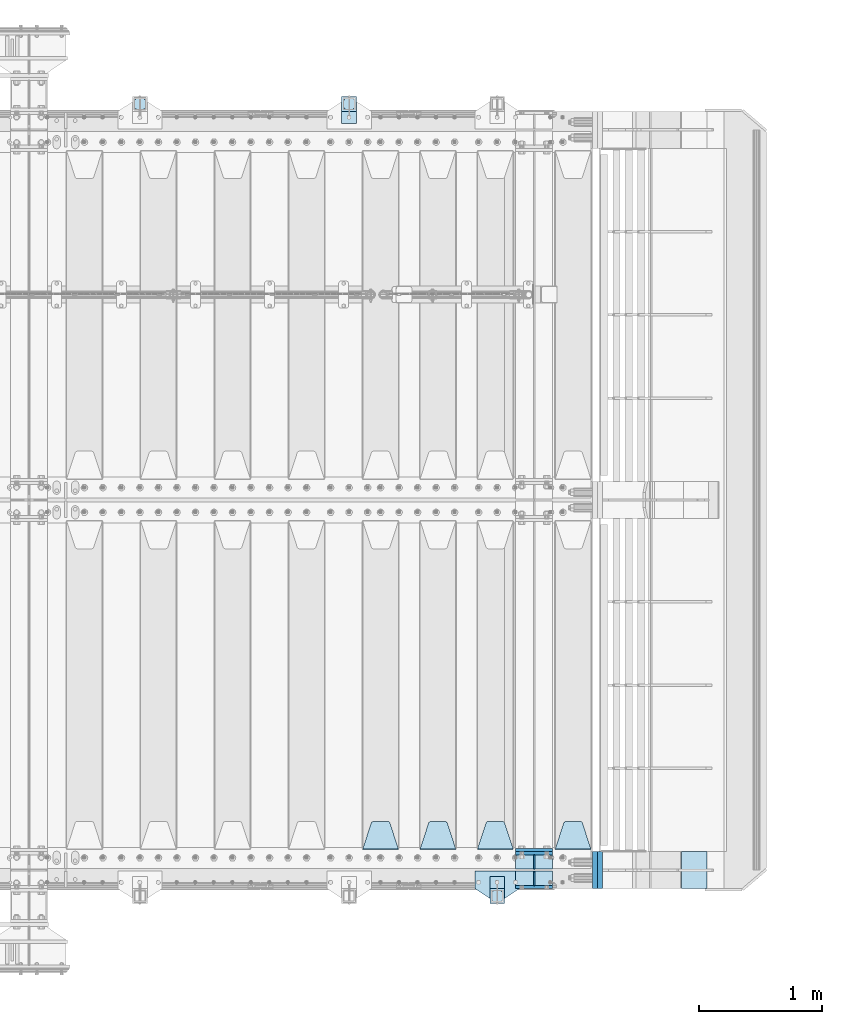
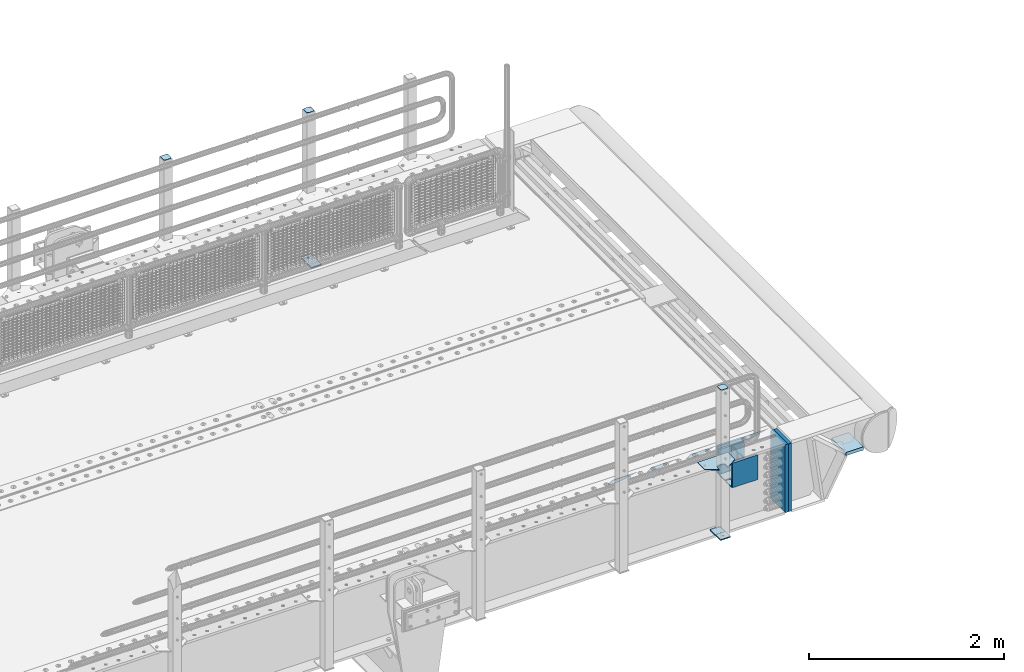
# One storey, part 188 of 208: 22 plates.
"""IFC2X3 building model written with IfcOpenShell, lengths in millimetres."""

from ifc_helpers import new_model, si_unit, frame, origin_with_axes, place, context, subcontext, project, spatial, faceted_brep, material, type_object, element, save


model = new_model("IFC2X3")

# Units and contexts
model_context = context("Model", 3, precision=1e-05, world=origin_with_axes())
body_context = subcontext(model_context, "Body", "Model", "MODEL_VIEW")
ifc_project = project(units=[si_unit("LENGTHUNIT", "METRE", prefix="MILLI"), si_unit("AREAUNIT", "SQUARE_METRE"), si_unit("VOLUMEUNIT", "CUBIC_METRE"), si_unit("MASSUNIT", "GRAM", prefix="KILO"), si_unit("TIMEUNIT", "SECOND"), si_unit("PLANEANGLEUNIT", "RADIAN"), si_unit("SOLIDANGLEUNIT", "STERADIAN"), si_unit("THERMODYNAMICTEMPERATUREUNIT", "DEGREE_CELSIUS"), si_unit("LUMINOUSINTENSITYUNIT", "LUMEN")], contexts=[model_context])

# Site, building, storey
site_placement = place(None, origin_with_axes())
site = spatial("IfcSite", under=ifc_project, at=site_placement, CompositionType="ELEMENT")
building_placement = place(site_placement, origin_with_axes())
building = spatial("IfcBuilding", under=site, at=building_placement, Name="Standard", CompositionType="ELEMENT")
storey_placement = place(building_placement, origin_with_axes())
storey = spatial("IfcBuildingStorey", under=building, at=storey_placement, Name="Undefined", CompositionType="ELEMENT", Elevation=0.0)

# Plates
ifc_material_1 = material(Name="STEEL/S355N")
plate_type_1 = type_object("IfcPlateType", PredefinedType="NOTDEFINED")
for number, where, z_axis, x_axis in (
    (1, (-26255.0, 137.499999999987, -339.999999999993), (0.0, 0.0, 1.0), (1.0, 0.0, 0.0)),
    (2, (-26255.0, -137.500000000013, -339.999999999993), (0.0, 0.0, 1.0), (1.0, 0.0, 0.0)),
):
    element("IfcPlate", number, at=place(storey_placement, frame(where, z_axis=z_axis, x_axis=x_axis)), inside=storey, type_object=plate_type_1, material=ifc_material_1, context=body_context, shape_type="Brep", body=[
        faceted_brep([(0.0, -12.5, 0.0), (0.0, -12.5, 310.0), (0.0, 12.5, 310.0), (0.0, 12.5, 0.0), (300.0, -12.5, 310.0), (300.0, 12.5, 310.0), (300.0, -12.5, 0.0), (300.0, 12.5, 0.0)], [[[0, 1, 2, 3]], [[1, 4, 5, 2]], [[4, 6, 7, 5]], [[6, 0, 3, 7]], [[5, 7, 3, 2]], [[6, 4, 1, 0]]]),
    ])
plate_1_placement = place(storey_placement, frame((-26255.0, 162.5, -340.000000000044), z_axis=(0.0, 0.0, 1.0), x_axis=(1.0, 0.0, 0.0)))
element("IfcPlate", 3, at=plate_1_placement, inside=storey, type_object=plate_type_1, material=ifc_material_1, context=body_context, shape_type="Brep", body=[
    faceted_brep([(0.0, -12.5, 0.0), (0.0, -12.5, 340.0), (0.0, 12.5, 340.0), (0.0, 12.5, 0.0), (300.0, -12.5, 340.0), (300.0, 12.5, 340.0), (300.0, -12.5, 0.0), (300.0, 12.5, 0.0)], [[[0, 1, 2, 3]], [[1, 4, 5, 2]], [[4, 6, 7, 5]], [[6, 0, 3, 7]], [[5, 7, 3, 2]], [[6, 4, 1, 0]]]),
])
plate_type_2 = type_object("IfcPlateType", PredefinedType="NOTDEFINED")
for number, where, z_axis, x_axis in (
    (4, (-26255.0, -8.0000000000133, -342.999999999993), (0.0, -1.0, 0.0), (1.0, 0.0, 0.0)),
    (5, (-26255.0, 7.9999999999867, -342.999999999993), (0.0, 1.0, 0.0), (1.0, 0.0, 0.0)),
):
    element("IfcPlate", number, at=place(storey_placement, frame(where, z_axis=z_axis, x_axis=x_axis)), inside=storey, type_object=plate_type_2, material=ifc_material_1, context=body_context, shape_type="Brep", body=[
        faceted_brep([(0.0, -7.0, 0.0), (0.0, -7.0, 117.0), (0.0, 7.0, 117.0), (0.0, 7.0, 0.0), (300.0, -7.0, 117.0), (300.0, 7.0, 117.0), (300.0, -7.0, 0.0), (300.0, 7.0, 0.0)], [[[0, 1, 2, 3]], [[1, 4, 5, 2]], [[4, 6, 7, 5]], [[6, 0, 3, 7]], [[5, 7, 3, 2]], [[6, 4, 1, 0]]]),
    ])
plate_type_3 = type_object("IfcPlateType", PredefinedType="NOTDEFINED")
for number, where, z_axis, x_axis in (
    (6, (-26105.0, 7.9999999999867, -29.999999999993), (0.0, 0.0, -1.0), (0.0, 1.0, 0.0)),
    (7, (-26105.0, -8.0000000000133, -29.999999999993), (0.0, 0.0, -1.0), (0.0, -1.0, 0.0)),
):
    element("IfcPlate", number, at=place(storey_placement, frame(where, z_axis=z_axis, x_axis=x_axis)), inside=storey, type_object=plate_type_3, material=ifc_material_1, context=body_context, shape_type="Brep", body=[
        faceted_brep([(0.0, -5.0, 30.0), (0.0, -5.0, 306.0), (0.0, 5.0, 306.0), (0.0, 5.0, 30.0), (117.0, -5.0, 306.0), (117.0, 5.0, 306.0), (117.0, -5.0, 0.0), (117.0, 5.0, 0.0), (30.0, -5.0, 0.0), (30.0, 5.0, 0.0), (24.7905546699922, -5.0, 0.455767409633758), (24.7905546699922, 5.0, 0.455767409633758), (19.7393957002296, -5.0, 1.80922137642275), (19.7393957002296, 5.0, 1.80922137642275), (15.0, -5.0, 4.01923788646684), (15.0, 5.0, 4.01923788646684), (10.7163717094036, -5.0, 7.01866670643066), (10.7163717094036, 5.0, 7.01866670643066), (7.01866670643085, -5.0, 10.7163717094038), (7.01866670643085, 5.0, 10.7163717094038), (4.01923788646673, -5.0, 15.0), (4.01923788646673, 5.0, 15.0), (1.80922137642301, -5.0, 19.7393957002299), (1.80922137642301, 5.0, 19.7393957002299), (0.455767409634063, -5.0, 24.7905546699921), (0.455767409634063, 5.0, 24.7905546699921)], [[[0, 1, 2, 3]], [[1, 4, 5, 2]], [[4, 6, 7, 5]], [[6, 8, 9, 7]], [[8, 10, 11, 9]], [[10, 12, 13, 11]], [[12, 14, 15, 13]], [[14, 16, 17, 15]], [[16, 18, 19, 17]], [[18, 20, 21, 19]], [[20, 22, 23, 21]], [[22, 24, 25, 23]], [[24, 0, 3, 25]], [[5, 7, 9, 11, 13, 15, 17, 19, 21, 23, 25, 3, 2]], [[24, 22, 20, 18, 16, 14, 12, 10, 8, 6, 4, 1, 0]]]),
    ])
plate_type_4 = type_object("IfcPlateType", PredefinedType="NOTDEFINED")
plate_2_placement = place(storey_placement, frame((-25645.0, 168.232233047019, -1.76776695296758), z_axis=(0.0, 0.707106781186547, -0.707106781186548), x_axis=(-1.0, 0.0, 0.0)))
element("IfcPlate", 8, at=plate_2_placement, inside=storey, type_object=plate_type_4, material=ifc_material_1, context=body_context, shape_type="Brep", body=[
    faceted_brep([(0.0, -2.5, 0.0), (69.345504679477, -2.5, 300.17173142483), (69.345504679477, 2.5, 300.17173142483), (0.0, 2.5, 0.0), (70.9274061199576, -2.5, 304.897442415399), (70.9274061199576, 2.5, 304.8974424154), (73.3818627772307, -2.5, 309.234538108527), (73.3818627772307, 2.5, 309.234538108527), (76.6187032999551, -2.5, 313.023683126103), (76.6187032999551, 2.5, 313.023683126103), (80.5190132704993, -2.5, 316.125672595371), (80.5190132704993, 2.5, 316.125672595371), (84.9395038596849, -2.5, 318.426546230476), (84.9395038596849, 2.50000000000091, 318.426546230476), (89.7177759439219, -2.5, 319.841774983275), (89.7177759439219, 2.50000000000091, 319.841774983275), (94.678286292652, -2.49999999999909, 320.319366455078), (94.678286292652, 2.5, 320.319366455078), (195.321713707348, -2.49999999999909, 320.319366455078), (195.321713707348, 2.5, 320.319366455078), (200.282224056078, -2.5, 319.841774983275), (200.282224056078, 2.5, 319.841774983274), (205.060496140315, -2.5, 318.426546230475), (205.060496140315, 2.5, 318.426546230475), (209.480986729501, -2.5, 316.125672595371), (209.480986729501, 2.50000000000091, 316.125672595371), (213.381296700045, -2.5, 313.023683126102), (213.381296700045, 2.5, 313.023683126102), (216.618137222769, -2.5, 309.234538108526), (216.618137222769, 2.5, 309.234538108527), (219.072593880042, -2.5, 304.897442415399), (219.072593880042, 2.5, 304.897442415399), (220.654495320523, -2.5, 300.17173142483), (220.654495320523, 2.5, 300.17173142483), (290.0, -2.5, 0.0), (290.0, 2.5, 0.0)], [[[0, 1, 2, 3]], [[1, 4, 5, 2]], [[4, 6, 7, 5]], [[6, 8, 9, 7]], [[8, 10, 11, 9]], [[10, 12, 13, 11]], [[12, 14, 15, 13]], [[14, 16, 17, 15]], [[16, 18, 19, 17]], [[18, 20, 21, 19]], [[20, 22, 23, 21]], [[22, 24, 25, 23]], [[24, 26, 27, 25]], [[26, 28, 29, 27]], [[28, 30, 31, 29]], [[30, 32, 33, 31]], [[32, 34, 35, 33]], [[34, 0, 3, 35]], [[5, 7, 9, 11, 13, 15, 17, 19, 21, 23, 25, 27, 29, 31, 33, 35, 3, 2]], [[34, 32, 30, 28, 26, 24, 22, 20, 18, 16, 14, 12, 10, 8, 6, 4, 1, 0]]]),
])
plate_3_placement = place(storey_placement, frame((-26275.0, 168.232233047019, -1.76776695296758), z_axis=(0.0, 0.707106781186547, -0.707106781186548), x_axis=(-1.0, 0.0, 0.0)))
element("IfcPlate", 9, at=plate_3_placement, inside=storey, type_object=plate_type_4, material=ifc_material_1, context=body_context, shape_type="Brep", body=[
    faceted_brep([(0.0, -2.5, 0.0), (69.345504679477, -2.5, 300.17173142483), (69.345504679477, 2.5, 300.17173142483), (0.0, 2.5, 0.0), (70.9274061199576, -2.5, 304.897442415399), (70.9274061199576, 2.5, 304.8974424154), (73.3818627772307, -2.5, 309.234538108527), (73.3818627772307, 2.5, 309.234538108527), (76.6187032999551, -2.5, 313.023683126103), (76.6187032999551, 2.5, 313.023683126103), (80.5190132704993, -2.5, 316.125672595371), (80.5190132704993, 2.5, 316.125672595371), (84.9395038596849, -2.5, 318.426546230476), (84.9395038596849, 2.50000000000091, 318.426546230476), (89.7177759439219, -2.5, 319.841774983275), (89.7177759439219, 2.50000000000091, 319.841774983275), (94.678286292652, -2.49999999999909, 320.319366455078), (94.678286292652, 2.5, 320.319366455078), (195.321713707348, -2.49999999999909, 320.319366455078), (195.321713707348, 2.5, 320.319366455078), (200.282224056078, -2.5, 319.841774983275), (200.282224056078, 2.5, 319.841774983274), (205.060496140315, -2.5, 318.426546230475), (205.060496140315, 2.5, 318.426546230475), (209.480986729501, -2.5, 316.125672595371), (209.480986729501, 2.50000000000091, 316.125672595371), (213.381296700045, -2.5, 313.023683126102), (213.381296700045, 2.5, 313.023683126102), (216.618137222769, -2.5, 309.234538108526), (216.618137222769, 2.5, 309.234538108527), (219.072593880042, -2.5, 304.897442415399), (219.072593880042, 2.5, 304.897442415399), (220.654495320523, -2.5, 300.17173142483), (220.654495320523, 2.5, 300.17173142483), (290.0, -2.5, 0.0), (290.0, 2.5, 0.0)], [[[0, 1, 2, 3]], [[1, 4, 5, 2]], [[4, 6, 7, 5]], [[6, 8, 9, 7]], [[8, 10, 11, 9]], [[10, 12, 13, 11]], [[12, 14, 15, 13]], [[14, 16, 17, 15]], [[16, 18, 19, 17]], [[18, 20, 21, 19]], [[20, 22, 23, 21]], [[22, 24, 25, 23]], [[24, 26, 27, 25]], [[26, 28, 29, 27]], [[28, 30, 31, 29]], [[30, 32, 33, 31]], [[32, 34, 35, 33]], [[34, 0, 3, 35]], [[5, 7, 9, 11, 13, 15, 17, 19, 21, 23, 25, 27, 29, 31, 33, 35, 3, 2]], [[34, 32, 30, 28, 26, 24, 22, 20, 18, 16, 14, 12, 10, 8, 6, 4, 1, 0]]]),
])
plate_4_placement = place(storey_placement, frame((-26740.0, 168.232233047019, -1.76776695296758), z_axis=(0.0, 0.707106781186547, -0.707106781186548), x_axis=(-1.0, 0.0, 0.0)))
element("IfcPlate", 10, at=plate_4_placement, inside=storey, type_object=plate_type_4, material=ifc_material_1, context=body_context, shape_type="Brep", body=[
    faceted_brep([(0.0, -2.5, 0.0), (69.345504679477, -2.5, 300.17173142483), (69.345504679477, 2.5, 300.17173142483), (0.0, 2.5, 0.0), (70.9274061199576, -2.5, 304.897442415399), (70.9274061199576, 2.5, 304.8974424154), (73.3818627772307, -2.5, 309.234538108527), (73.3818627772307, 2.5, 309.234538108527), (76.6187032999551, -2.5, 313.023683126103), (76.6187032999551, 2.5, 313.023683126103), (80.5190132704993, -2.5, 316.125672595371), (80.5190132704993, 2.5, 316.125672595371), (84.9395038596849, -2.5, 318.426546230476), (84.9395038596849, 2.50000000000091, 318.426546230476), (89.7177759439219, -2.5, 319.841774983275), (89.7177759439219, 2.50000000000091, 319.841774983275), (94.678286292652, -2.49999999999909, 320.319366455078), (94.678286292652, 2.5, 320.319366455078), (195.321713707348, -2.49999999999909, 320.319366455078), (195.321713707348, 2.5, 320.319366455078), (200.282224056078, -2.5, 319.841774983275), (200.282224056078, 2.5, 319.841774983274), (205.060496140315, -2.5, 318.426546230475), (205.060496140315, 2.5, 318.426546230475), (209.480986729501, -2.5, 316.125672595371), (209.480986729501, 2.50000000000091, 316.125672595371), (213.381296700045, -2.5, 313.023683126102), (213.381296700045, 2.5, 313.023683126102), (216.618137222769, -2.5, 309.234538108526), (216.618137222769, 2.5, 309.234538108527), (219.072593880042, -2.5, 304.897442415399), (219.072593880042, 2.5, 304.897442415399), (220.654495320523, -2.5, 300.17173142483), (220.654495320523, 2.5, 300.17173142483), (290.0, -2.5, 0.0), (290.0, 2.5, 0.0)], [[[0, 1, 2, 3]], [[1, 4, 5, 2]], [[4, 6, 7, 5]], [[6, 8, 9, 7]], [[8, 10, 11, 9]], [[10, 12, 13, 11]], [[12, 14, 15, 13]], [[14, 16, 17, 15]], [[16, 18, 19, 17]], [[18, 20, 21, 19]], [[20, 22, 23, 21]], [[22, 24, 25, 23]], [[24, 26, 27, 25]], [[26, 28, 29, 27]], [[28, 30, 31, 29]], [[30, 32, 33, 31]], [[32, 34, 35, 33]], [[34, 0, 3, 35]], [[5, 7, 9, 11, 13, 15, 17, 19, 21, 23, 25, 27, 29, 31, 33, 35, 3, 2]], [[34, 32, 30, 28, 26, 24, 22, 20, 18, 16, 14, 12, 10, 8, 6, 4, 1, 0]]]),
])
plate_5_placement = place(storey_placement, frame((-27205.0, 168.232233047019, -1.76776695296758), z_axis=(0.0, 0.707106781186547, -0.707106781186548), x_axis=(-1.0, 0.0, 0.0)))
element("IfcPlate", 11, at=plate_5_placement, inside=storey, type_object=plate_type_4, material=ifc_material_1, context=body_context, shape_type="Brep", body=[
    faceted_brep([(0.0, -2.5, 0.0), (69.345504679477, -2.5, 300.17173142483), (69.345504679477, 2.5, 300.17173142483), (0.0, 2.5, 0.0), (70.9274061199576, -2.5, 304.897442415399), (70.9274061199576, 2.5, 304.8974424154), (73.3818627772307, -2.5, 309.234538108527), (73.3818627772307, 2.5, 309.234538108527), (76.6187032999551, -2.5, 313.023683126103), (76.6187032999551, 2.5, 313.023683126103), (80.5190132704993, -2.5, 316.125672595371), (80.5190132704993, 2.5, 316.125672595371), (84.9395038596849, -2.5, 318.426546230476), (84.9395038596849, 2.50000000000091, 318.426546230476), (89.7177759439219, -2.5, 319.841774983275), (89.7177759439219, 2.50000000000091, 319.841774983275), (94.678286292652, -2.49999999999909, 320.319366455078), (94.678286292652, 2.5, 320.319366455078), (195.321713707348, -2.49999999999909, 320.319366455078), (195.321713707348, 2.5, 320.319366455078), (200.282224056078, -2.5, 319.841774983275), (200.282224056078, 2.5, 319.841774983274), (205.060496140315, -2.5, 318.426546230475), (205.060496140315, 2.5, 318.426546230475), (209.480986729501, -2.5, 316.125672595371), (209.480986729501, 2.50000000000091, 316.125672595371), (213.381296700045, -2.5, 313.023683126102), (213.381296700045, 2.5, 313.023683126102), (216.618137222769, -2.5, 309.234538108526), (216.618137222769, 2.5, 309.234538108527), (219.072593880042, -2.5, 304.897442415399), (219.072593880042, 2.5, 304.897442415399), (220.654495320523, -2.5, 300.17173142483), (220.654495320523, 2.5, 300.17173142483), (290.0, -2.5, 0.0), (290.0, 2.5, 0.0)], [[[0, 1, 2, 3]], [[1, 4, 5, 2]], [[4, 6, 7, 5]], [[6, 8, 9, 7]], [[8, 10, 11, 9]], [[10, 12, 13, 11]], [[12, 14, 15, 13]], [[14, 16, 17, 15]], [[16, 18, 19, 17]], [[18, 20, 21, 19]], [[20, 22, 23, 21]], [[22, 24, 25, 23]], [[24, 26, 27, 25]], [[26, 28, 29, 27]], [[28, 30, 31, 29]], [[30, 32, 33, 31]], [[32, 34, 35, 33]], [[34, 0, 3, 35]], [[5, 7, 9, 11, 13, 15, 17, 19, 21, 23, 25, 27, 29, 31, 33, 35, 3, 2]], [[34, 32, 30, 28, 26, 24, 22, 20, 18, 16, 14, 12, 10, 8, 6, 4, 1, 0]]]),
])
ifc_material_2 = material(Name="STEEL/S355J2")
plate_type_5 = type_object("IfcPlateType", PredefinedType="NOTDEFINED")
plate_6_placement = place(storey_placement, frame((-26225.0, -4.99999999999636, 5.00000000004911), z_axis=(0.0, -1.0, 0.0), x_axis=(-1.0, 0.0, 0.0)))
element("IfcPlate", 12, at=plate_6_placement, inside=storey, type_object=plate_type_5, material=ifc_material_2, context=body_context, shape_type="Brep", body=[
    faceted_brep([(0.0, -5.0, 0.0), (2.31396552408114e-06, -5.0, 145.0), (2.31396552408114e-06, 5.0, 145.0), (0.0, 5.0, 0.0), (130.0, -5.0, 230.0), (130.0, 5.0, 230.0), (130.0, -5.0, 180.0), (130.0, 5.0, 180.0), (130.48036798992, -5.0, 175.122741949597), (130.48036798992, 5.0, 175.122741949597), (131.903011687216, -5.0, 170.432914190873), (131.903011687216, 5.0, 170.432914190873), (134.213259692435, -5.0, 166.11074417451), (134.213259692435, 5.0, 166.11074417451), (137.322330470335, -5.0, 162.322330470336), (137.322330470335, 5.0, 162.322330470336), (141.110744174512, -5.0, 159.213259692437), (141.110744174512, 5.0, 159.213259692437), (145.432914190871, -5.0, 156.903011687218), (145.432914190871, 5.0, 156.903011687218), (150.122741949595, -5.0, 155.48036798992), (150.122741949595, 5.0, 155.48036798992), (155.0, -5.0, 155.0), (155.0, 5.0, 155.0), (205.0, -5.0, 155.0), (205.0, 5.0, 155.0), (209.877258050405, -5.0, 155.48036798992), (209.877258050405, 5.0, 155.48036798992), (214.567085809129, -5.0, 156.903011687218), (214.567085809129, 5.0, 156.903011687218), (218.889255825488, -5.0, 159.213259692437), (218.889255825488, 5.0, 159.213259692437), (222.677669529665, -5.0, 162.322330470336), (222.677669529665, 5.0, 162.322330470336), (225.786740307565, -5.0, 166.11074417451), (225.786740307565, 5.0, 166.11074417451), (228.096988312784, -5.0, 170.432914190873), (228.096988312784, 5.0, 170.432914190873), (229.51963201008, -5.0, 175.122741949597), (229.51963201008, 5.0, 175.122741949597), (230.0, -5.0, 180.0), (230.0, 5.0, 180.0), (230.0, -5.0, 230.0), (230.0, 5.0, 230.0), (360.0, -5.0, 145.0), (360.0, 5.0, 145.0), (360.0, -5.0, -7.27595761418343e-12), (360.0, 5.0, -7.27595761418343e-12)], [[[0, 1, 2, 3]], [[1, 4, 5, 2]], [[4, 6, 7, 5]], [[6, 8, 9, 7]], [[8, 10, 11, 9]], [[10, 12, 13, 11]], [[12, 14, 15, 13]], [[14, 16, 17, 15]], [[16, 18, 19, 17]], [[18, 20, 21, 19]], [[20, 22, 23, 21]], [[22, 24, 25, 23]], [[24, 26, 27, 25]], [[26, 28, 29, 27]], [[28, 30, 31, 29]], [[30, 32, 33, 31]], [[32, 34, 35, 33]], [[34, 36, 37, 35]], [[36, 38, 39, 37]], [[38, 40, 41, 39]], [[40, 42, 43, 41]], [[42, 44, 45, 43]], [[44, 46, 47, 45]], [[46, 0, 3, 47]], [[5, 7, 9, 11, 13, 15, 17, 19, 21, 23, 25, 27, 29, 31, 33, 35, 37, 39, 41, 43, 45, 47, 3, 2]], [[46, 44, 42, 40, 38, 36, 34, 32, 30, 28, 26, 24, 22, 20, 18, 16, 14, 12, 10, 8, 6, 4, 1, 0]]]),
])
plate_type_6 = type_object("IfcPlateType", PredefinedType="NOTDEFINED")
plate_7_placement = place(storey_placement, frame((-27664.9999999999, 6050.00000000021, -850.000000000002), z_axis=(0.0, 1.0, 0.0), x_axis=(1.0, 0.0, 0.0)))
element("IfcPlate", 13, at=plate_7_placement, inside=storey, type_object=plate_type_6, material=ifc_material_2, context=body_context, shape_type="Brep", body=[
    faceted_brep([(66.3639610305399, -5.0, 163.636038969112), (66.3639610305399, 5.0, 163.636038969112), (59.9999999998618, 5.0, 160.999999999791), (59.9999999998618, -5.0, 160.999999999791), (53.6360389691836, 5.0, 163.636038969112), (53.6360389691836, -5.0, 163.636038969112), (50.9999999998618, 5.0, 169.999999999791), (50.9999999998618, -5.0, 169.999999999791), (53.6360389691836, 5.0, 176.36396103047), (53.6360389691836, -5.0, 176.36396103047), (59.9999999998618, 5.0, 178.999999999791), (59.9999999998618, -5.0, 178.999999999791), (66.3639610305399, 5.0, 176.36396103047), (66.3639610305399, -5.0, 176.36396103047), (68.9999999998618, 5.0, 169.999999999791), (68.9999999998618, -5.0, 169.999999999791), (120.0, -5.0, 0.0), (120.0, -5.0, 220.0), (0.0, -5.0, 220.0), (0.0, -5.0, 0.0), (0.0, 5.0, 0.0), (120.0, 5.0, 0.0), (120.0, 5.0, 220.0), (0.0, 5.0, 220.0)], [[[0, 1, 2, 3]], [[3, 2, 4, 5]], [[5, 4, 6, 7]], [[7, 6, 8, 9]], [[9, 8, 10, 11]], [[11, 10, 12, 13]], [[13, 12, 14, 15]], [[15, 14, 1, 0]], [[16, 17, 18, 19], [3, 5, 7, 9, 11, 13, 15, 0]], [[16, 19, 20, 21]], [[17, 16, 21, 22]], [[18, 17, 22, 23]], [[19, 18, 23, 20]], [[22, 21, 20, 23], [10, 8, 6, 4, 2, 1, 14, 12]]]),
])
plate_8_placement = place(storey_placement, frame((-26345.0000000001, -50.0000000002074, -850.000000000002), z_axis=(0.0, -1.0, 0.0), x_axis=(-1.0, 0.0, 0.0)))
element("IfcPlate", 14, at=plate_8_placement, inside=storey, type_object=plate_type_6, material=ifc_material_2, context=body_context, shape_type="Brep", body=[
    faceted_brep([(53.6360389691836, -5.0, 176.36396103047), (53.6360389691836, 5.0, 176.36396103047), (59.9999999998618, 5.0, 178.999999999791), (59.9999999998618, -5.0, 178.999999999791), (66.3639610305399, 5.0, 176.36396103047), (66.3639610305399, -5.0, 176.36396103047), (68.9999999998618, 5.0, 169.999999999791), (68.9999999998618, -5.0, 169.999999999791), (66.3639610305399, 5.0, 163.636038969112), (66.3639610305399, -5.0, 163.636038969112), (59.9999999998618, 5.0, 160.999999999791), (59.9999999998618, -5.0, 160.999999999791), (53.6360389691836, 5.0, 163.636038969112), (53.6360389691836, -5.0, 163.636038969112), (50.9999999998618, 5.0, 169.999999999791), (50.9999999998618, -5.0, 169.999999999791), (120.0, -5.0, 0.0), (120.0, -5.0, 220.0), (0.0, -5.0, 220.0), (0.0, -5.0, 0.0), (0.0, 5.0, 0.0), (120.0, 5.0, 0.0), (120.0, 5.0, 220.0), (0.0, 5.0, 220.0)], [[[0, 1, 2, 3]], [[3, 2, 4, 5]], [[5, 4, 6, 7]], [[7, 6, 8, 9]], [[9, 8, 10, 11]], [[11, 10, 12, 13]], [[13, 12, 14, 15]], [[15, 14, 1, 0]], [[16, 17, 18, 19], [11, 13, 15, 0, 3, 5, 7, 9]], [[16, 19, 20, 21]], [[17, 16, 21, 22]], [[18, 17, 22, 23]], [[19, 18, 23, 20]], [[22, 21, 20, 23], [2, 1, 14, 12, 10, 8, 6, 4]]]),
])
plate_type_7 = type_object("IfcPlateType", PredefinedType="NOTDEFINED")
plate_9_placement = place(storey_placement, frame((-27560.9999999999, 6166.00000000021, 1012.50000000001), z_axis=(0.0, 1.0, 0.0), x_axis=(-1.0, 0.0, 0.0)))
element("IfcPlate", 15, at=plate_9_placement, inside=storey, type_object=plate_type_7, material=ifc_material_2, context=body_context, shape_type="Brep", body=[
    faceted_brep([(0.0, -2.5, 19.0), (0.0, -2.5, 69.0), (0.0, 2.5, 69.0), (0.0, 2.5, 19.0), (0.476369668544066, -2.5, 73.2278977451697), (0.476369668544066, 2.5, 73.2278977451697), (1.88159150985302, -2.5, 77.2437910432336), (1.88159150985302, 2.5, 77.2437910432336), (4.14520183310742, -2.5, 80.8463062353158), (4.14520183310742, 2.5, 80.8463062353158), (7.15369376468516, -2.5, 83.8547981668926), (7.15369376468516, 2.5, 83.8547981668926), (10.7562089567655, -2.5, 86.1184084901461), (10.7562089567655, 2.5, 86.1184084901461), (14.7721022548285, -2.5, 87.523630331455), (14.7721022548285, 2.5, 87.523630331455), (19.0, -2.5, 88.0), (19.0, 2.5, 88.0), (69.0, -2.5, 88.0), (69.0, 2.5, 88.0), (73.2278977451715, -2.5, 87.523630331455), (73.2278977451715, 2.5, 87.523630331455), (77.2437910432345, -2.5, 86.1184084901461), (77.2437910432345, 2.5, 86.1184084901461), (80.8463062353148, -2.5, 83.8547981668926), (80.8463062353148, 2.5, 83.8547981668926), (83.8547981668926, -2.5, 80.8463062353158), (83.8547981668926, 2.5, 80.8463062353158), (86.118408490147, -2.5, 77.2437910432336), (86.118408490147, 2.5, 77.2437910432336), (87.5236303314559, -2.5, 73.2278977451697), (87.5236303314559, 2.5, 73.2278977451697), (88.0, -2.5, 69.0), (88.0, 2.5, 69.0), (88.0, -2.5, 19.0), (88.0, 2.5, 19.0), (87.5236303314559, -2.5, 14.7721022548303), (87.5236303314559, 2.5, 14.7721022548303), (86.118408490147, -2.5, 10.7562089567664), (86.118408490147, 2.5, 10.7562089567664), (83.8547981668926, -2.5, 7.15369376468425), (83.8547981668926, 2.5, 7.15369376468425), (80.8463062353148, -2.5, 4.14520183310742), (80.8463062353148, 2.5, 4.14520183310742), (77.2437910432345, -2.5, 1.88159150985393), (77.2437910432345, 2.5, 1.88159150985393), (73.2278977451715, -2.5, 0.476369668544976), (73.2278977451715, 2.5, 0.476369668544976), (69.0, -2.5, 0.0), (69.0, 2.5, 0.0), (19.0, -2.5, 0.0), (19.0, 2.5, 0.0), (14.7721022548285, -2.5, 0.476369668544976), (14.7721022548285, 2.5, 0.476369668544976), (10.7562089567655, -2.5, 1.88159150985393), (10.7562089567655, 2.5, 1.88159150985393), (7.15369376468516, -2.5, 4.14520183310742), (7.15369376468516, 2.5, 4.14520183310742), (4.14520183310742, -2.5, 7.15369376468425), (4.14520183310742, 2.5, 7.15369376468425), (1.88159150985302, -2.5, 10.7562089567664), (1.88159150985302, 2.5, 10.7562089567664), (0.476369668544066, -2.5, 14.7721022548303), (0.476369668544066, 2.5, 14.7721022548303)], [[[0, 1, 2, 3]], [[1, 4, 5, 2]], [[4, 6, 7, 5]], [[6, 8, 9, 7]], [[8, 10, 11, 9]], [[10, 12, 13, 11]], [[12, 14, 15, 13]], [[14, 16, 17, 15]], [[16, 18, 19, 17]], [[18, 20, 21, 19]], [[20, 22, 23, 21]], [[22, 24, 25, 23]], [[24, 26, 27, 25]], [[26, 28, 29, 27]], [[28, 30, 31, 29]], [[30, 32, 33, 31]], [[32, 34, 35, 33]], [[34, 36, 37, 35]], [[36, 38, 39, 37]], [[38, 40, 41, 39]], [[40, 42, 43, 41]], [[42, 44, 45, 43]], [[44, 46, 47, 45]], [[46, 48, 49, 47]], [[48, 50, 51, 49]], [[50, 52, 53, 51]], [[52, 54, 55, 53]], [[54, 56, 57, 55]], [[56, 58, 59, 57]], [[58, 60, 61, 59]], [[60, 62, 63, 61]], [[62, 0, 3, 63]], [[5, 7, 9, 11, 13, 15, 17, 19, 21, 23, 25, 27, 29, 31, 33, 35, 37, 39, 41, 43, 45, 47, 49, 51, 53, 55, 57, 59, 61, 63, 3, 2]], [[62, 60, 58, 56, 54, 52, 50, 48, 46, 44, 42, 40, 38, 36, 34, 32, 30, 28, 26, 24, 22, 20, 18, 16, 14, 12, 10, 8, 6, 4, 1, 0]]]),
])
plate_10_placement = place(storey_placement, frame((-29255.9999999999, 6166.00000000021, 1012.50000000001), z_axis=(0.0, 1.0, 0.0), x_axis=(-1.0, 0.0, 0.0)))
element("IfcPlate", 16, at=plate_10_placement, inside=storey, type_object=plate_type_7, material=ifc_material_2, context=body_context, shape_type="Brep", body=[
    faceted_brep([(0.0, -2.5, 19.0), (0.0, -2.5, 69.0), (0.0, 2.5, 69.0), (0.0, 2.5, 19.0), (0.476369668544066, -2.5, 73.2278977451697), (0.476369668544066, 2.5, 73.2278977451697), (1.88159150985302, -2.5, 77.2437910432336), (1.88159150985302, 2.5, 77.2437910432336), (4.14520183310742, -2.5, 80.8463062353158), (4.14520183310742, 2.5, 80.8463062353158), (7.15369376468516, -2.5, 83.8547981668926), (7.15369376468516, 2.5, 83.8547981668926), (10.7562089567655, -2.5, 86.1184084901461), (10.7562089567655, 2.5, 86.1184084901461), (14.7721022548285, -2.5, 87.523630331455), (14.7721022548285, 2.5, 87.523630331455), (19.0, -2.5, 88.0), (19.0, 2.5, 88.0), (69.0, -2.5, 88.0), (69.0, 2.5, 88.0), (73.2278977451715, -2.5, 87.523630331455), (73.2278977451715, 2.5, 87.523630331455), (77.2437910432345, -2.5, 86.1184084901461), (77.2437910432345, 2.5, 86.1184084901461), (80.8463062353148, -2.5, 83.8547981668926), (80.8463062353148, 2.5, 83.8547981668926), (83.8547981668926, -2.5, 80.8463062353158), (83.8547981668926, 2.5, 80.8463062353158), (86.118408490147, -2.5, 77.2437910432336), (86.118408490147, 2.5, 77.2437910432336), (87.5236303314559, -2.5, 73.2278977451697), (87.5236303314559, 2.5, 73.2278977451697), (88.0, -2.5, 69.0), (88.0, 2.5, 69.0), (88.0, -2.5, 19.0), (88.0, 2.5, 19.0), (87.5236303314559, -2.5, 14.7721022548303), (87.5236303314559, 2.5, 14.7721022548303), (86.118408490147, -2.5, 10.7562089567664), (86.118408490147, 2.5, 10.7562089567664), (83.8547981668926, -2.5, 7.15369376468425), (83.8547981668926, 2.5, 7.15369376468425), (80.8463062353148, -2.5, 4.14520183310742), (80.8463062353148, 2.5, 4.14520183310742), (77.2437910432345, -2.5, 1.88159150985393), (77.2437910432345, 2.5, 1.88159150985393), (73.2278977451715, -2.5, 0.476369668544976), (73.2278977451715, 2.5, 0.476369668544976), (69.0, -2.5, 0.0), (69.0, 2.5, 0.0), (19.0, -2.5, 0.0), (19.0, 2.5, 0.0), (14.7721022548285, -2.5, 0.476369668544976), (14.7721022548285, 2.5, 0.476369668544976), (10.7562089567655, -2.5, 1.88159150985393), (10.7562089567655, 2.5, 1.88159150985393), (7.15369376468516, -2.5, 4.14520183310742), (7.15369376468516, 2.5, 4.14520183310742), (4.14520183310742, -2.5, 7.15369376468425), (4.14520183310742, 2.5, 7.15369376468425), (1.88159150985302, -2.5, 10.7562089567664), (1.88159150985302, 2.5, 10.7562089567664), (0.476369668544066, -2.5, 14.7721022548303), (0.476369668544066, 2.5, 14.7721022548303)], [[[0, 1, 2, 3]], [[1, 4, 5, 2]], [[4, 6, 7, 5]], [[6, 8, 9, 7]], [[8, 10, 11, 9]], [[10, 12, 13, 11]], [[12, 14, 15, 13]], [[14, 16, 17, 15]], [[16, 18, 19, 17]], [[18, 20, 21, 19]], [[20, 22, 23, 21]], [[22, 24, 25, 23]], [[24, 26, 27, 25]], [[26, 28, 29, 27]], [[28, 30, 31, 29]], [[30, 32, 33, 31]], [[32, 34, 35, 33]], [[34, 36, 37, 35]], [[36, 38, 39, 37]], [[38, 40, 41, 39]], [[40, 42, 43, 41]], [[42, 44, 45, 43]], [[44, 46, 47, 45]], [[46, 48, 49, 47]], [[48, 50, 51, 49]], [[50, 52, 53, 51]], [[52, 54, 55, 53]], [[54, 56, 57, 55]], [[56, 58, 59, 57]], [[58, 60, 61, 59]], [[60, 62, 63, 61]], [[62, 0, 3, 63]], [[5, 7, 9, 11, 13, 15, 17, 19, 21, 23, 25, 27, 29, 31, 33, 35, 37, 39, 41, 43, 45, 47, 49, 51, 53, 55, 57, 59, 61, 63, 3, 2]], [[62, 60, 58, 56, 54, 52, 50, 48, 46, 44, 42, 40, 38, 36, 34, 32, 30, 28, 26, 24, 22, 20, 18, 16, 14, 12, 10, 8, 6, 4, 1, 0]]]),
])
plate_11_placement = place(storey_placement, frame((-26449.0000000001, -166.000000000207, 1012.50000000001), z_axis=(0.0, -1.0, 0.0), x_axis=(1.0, 0.0, 0.0)))
element("IfcPlate", 17, at=plate_11_placement, inside=storey, type_object=plate_type_7, material=ifc_material_2, context=body_context, shape_type="Brep", body=[
    faceted_brep([(0.0, -2.5, 19.0), (0.0, -2.5, 69.0), (0.0, 2.5, 69.0), (0.0, 2.5, 19.0), (0.476369668544066, -2.5, 73.2278977451697), (0.476369668544066, 2.5, 73.2278977451697), (1.88159150985302, -2.5, 77.2437910432336), (1.88159150985302, 2.5, 77.2437910432336), (4.14520183310742, -2.5, 80.8463062353158), (4.14520183310742, 2.5, 80.8463062353158), (7.15369376468516, -2.5, 83.8547981668926), (7.15369376468516, 2.5, 83.8547981668926), (10.7562089567655, -2.5, 86.1184084901461), (10.7562089567655, 2.5, 86.1184084901461), (14.7721022548285, -2.5, 87.523630331455), (14.7721022548285, 2.5, 87.523630331455), (19.0, -2.5, 88.0), (19.0, 2.5, 88.0), (69.0, -2.5, 88.0), (69.0, 2.5, 88.0), (73.2278977451715, -2.5, 87.523630331455), (73.2278977451715, 2.5, 87.523630331455), (77.2437910432345, -2.5, 86.1184084901461), (77.2437910432345, 2.5, 86.1184084901461), (80.8463062353148, -2.5, 83.8547981668926), (80.8463062353148, 2.5, 83.8547981668926), (83.8547981668926, -2.5, 80.8463062353158), (83.8547981668926, 2.5, 80.8463062353158), (86.118408490147, -2.5, 77.2437910432336), (86.118408490147, 2.5, 77.2437910432336), (87.5236303314559, -2.5, 73.2278977451697), (87.5236303314559, 2.5, 73.2278977451697), (88.0, -2.5, 69.0), (88.0, 2.5, 69.0), (88.0, -2.5, 19.0), (88.0, 2.5, 19.0), (87.5236303314559, -2.5, 14.7721022548303), (87.5236303314559, 2.5, 14.7721022548303), (86.118408490147, -2.5, 10.7562089567664), (86.118408490147, 2.5, 10.7562089567664), (83.8547981668926, -2.5, 7.15369376468425), (83.8547981668926, 2.5, 7.15369376468425), (80.8463062353148, -2.5, 4.14520183310742), (80.8463062353148, 2.5, 4.14520183310742), (77.2437910432345, -2.5, 1.88159150985393), (77.2437910432345, 2.5, 1.88159150985393), (73.2278977451715, -2.5, 0.476369668544976), (73.2278977451715, 2.5, 0.476369668544976), (69.0, -2.5, 0.0), (69.0, 2.5, 0.0), (19.0, -2.5, 0.0), (19.0, 2.5, 0.0), (14.7721022548285, -2.5, 0.476369668544976), (14.7721022548285, 2.5, 0.476369668544976), (10.7562089567655, -2.5, 1.88159150985393), (10.7562089567655, 2.5, 1.88159150985393), (7.15369376468516, -2.5, 4.14520183310742), (7.15369376468516, 2.5, 4.14520183310742), (4.14520183310742, -2.5, 7.15369376468425), (4.14520183310742, 2.5, 7.15369376468425), (1.88159150985302, -2.5, 10.7562089567664), (1.88159150985302, 2.5, 10.7562089567664), (0.476369668544066, -2.5, 14.7721022548303), (0.476369668544066, 2.5, 14.7721022548303)], [[[0, 1, 2, 3]], [[1, 4, 5, 2]], [[4, 6, 7, 5]], [[6, 8, 9, 7]], [[8, 10, 11, 9]], [[10, 12, 13, 11]], [[12, 14, 15, 13]], [[14, 16, 17, 15]], [[16, 18, 19, 17]], [[18, 20, 21, 19]], [[20, 22, 23, 21]], [[22, 24, 25, 23]], [[24, 26, 27, 25]], [[26, 28, 29, 27]], [[28, 30, 31, 29]], [[30, 32, 33, 31]], [[32, 34, 35, 33]], [[34, 36, 37, 35]], [[36, 38, 39, 37]], [[38, 40, 41, 39]], [[40, 42, 43, 41]], [[42, 44, 45, 43]], [[44, 46, 47, 45]], [[46, 48, 49, 47]], [[48, 50, 51, 49]], [[50, 52, 53, 51]], [[52, 54, 55, 53]], [[54, 56, 57, 55]], [[56, 58, 59, 57]], [[58, 60, 61, 59]], [[60, 62, 63, 61]], [[62, 0, 3, 63]], [[5, 7, 9, 11, 13, 15, 17, 19, 21, 23, 25, 27, 29, 31, 33, 35, 37, 39, 41, 43, 45, 47, 49, 51, 53, 55, 57, 59, 61, 63, 3, 2]], [[62, 60, 58, 56, 54, 52, 50, 48, 46, 44, 42, 40, 38, 36, 34, 32, 30, 28, 26, 24, 22, 20, 18, 16, 14, 12, 10, 8, 6, 4, 1, 0]]]),
])
plate_type_8 = type_object("IfcPlateType", PredefinedType="NOTDEFINED")
for number, where, z_axis, x_axis in (
    (18, (-27664.9999999999, 6050.00000000021, -857.500000000002), (0.0, 1.0, 0.0), (1.0, 0.0, 0.0)),
    (19, (-26345.0000000001, -50.0000000002074, -857.500000000002), (0.0, -1.0, 0.0), (-1.0, 0.0, 0.0)),
):
    element("IfcPlate", number, at=place(storey_placement, frame(where, z_axis=z_axis, x_axis=x_axis)), inside=storey, type_object=plate_type_8, material=ifc_material_2, context=body_context, shape_type="Brep", body=[
        faceted_brep([(0.0, -2.5, 0.0), (0.0, -2.5, 100.0), (0.0, 2.5, 100.0), (0.0, 2.5, 0.0), (120.0, -2.5, 100.0), (120.0, 2.5, 100.0), (120.0, -2.5, 0.0), (120.0, 2.5, 0.0)], [[[0, 1, 2, 3]], [[1, 4, 5, 2]], [[4, 6, 7, 5]], [[6, 0, 3, 7]], [[5, 7, 3, 2]], [[6, 4, 1, 0]]]),
    ])
plate_type_9 = type_object("IfcPlateType", PredefinedType="NOTDEFINED")
plate_12_placement = place(storey_placement, frame((-24911.0011701102, -150.000000000797, -387.999999998984), z_axis=(1.0, 0.0, 0.0), x_axis=(0.0, 1.0, 0.0)))
element("IfcPlate", 20, at=plate_12_placement, inside=storey, type_object=plate_type_9, material=ifc_material_1, context=body_context, shape_type="Brep", body=[
    faceted_brep([(0.0, -20.0, 0.0), (3.31056071445346e-10, -20.0, 208.0), (3.31056071445346e-10, 20.0, 208.0), (0.0, 20.0, 0.0), (300.0, -20.0, 208.0), (300.0, 20.0, 208.0), (300.0, -20.0, 3.63797880709171e-12), (300.0, 20.0, 3.63797880709171e-12)], [[[0, 1, 2, 3]], [[1, 4, 5, 2]], [[4, 6, 7, 5]], [[6, 0, 3, 7]], [[5, 7, 3, 2]], [[6, 4, 1, 0]]]),
])
ifc_material_3 = material()
plate_type_10 = type_object("IfcPlateType", PredefinedType="NOTDEFINED")
for number, where, z_axis, x_axis in (
    (21, (-25573.0011701093, 150.0, -869.999999999685), (0.0, 0.0, 1.0), (0.0, -1.0, 0.0)),
    (22, (-25613.0, 150.0, -870.0), (0.0, 0.0, 1.0), (0.0, -1.0, 0.0)),
):
    element("IfcPlate", number, at=place(storey_placement, frame(where, z_axis=z_axis, x_axis=x_axis)), inside=storey, type_object=plate_type_10, material=ifc_material_3, context=body_context, shape_type="Brep", body=[
        faceted_brep([(0.0, -20.0, 0.0), (9.5367431640625e-07, -20.0, 850.0), (9.5367431640625e-07, 20.0, 850.0), (0.0, 20.0, 0.0), (300.0, -20.0, 850.0), (300.0, 20.0, 850.0), (300.0, -20.0, 3.63797880709171e-12), (300.0, 20.0, 3.63797880709171e-12)], [[[0, 1, 2, 3]], [[1, 4, 5, 2]], [[4, 6, 7, 5]], [[6, 0, 3, 7]], [[5, 7, 3, 2]], [[6, 4, 1, 0]]]),
    ])

save(model, "model.ifc")
